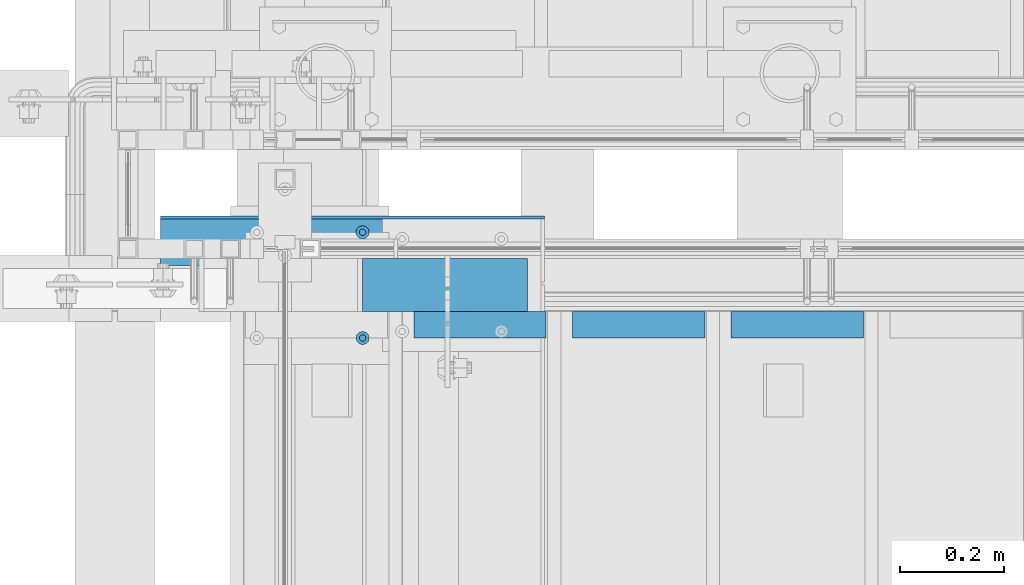
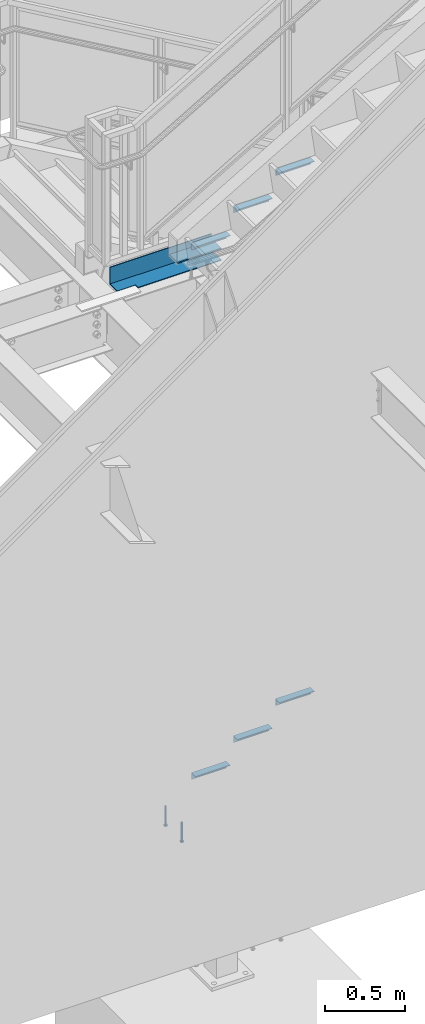
# One storey, part 913 of 1179: 10 beams, 4 elements without a shape of their own.
"""IFC2X3 building model written with IfcOpenShell, lengths in millimetres."""

from ifc_helpers import new_model, si_unit, frame, origin_with_axes, place, context, subcontext, project, spatial, faceted_brep, material, type_object, element, aggregate, save


model = new_model("IFC2X3")

# Units and contexts
model_context = context("Model", 3, precision=1e-05, world=origin_with_axes())
body_context = subcontext(model_context, "Body", "Model", "MODEL_VIEW")
ifc_project = project(units=[si_unit("LENGTHUNIT", "METRE", prefix="MILLI"), si_unit("AREAUNIT", "SQUARE_METRE"), si_unit("VOLUMEUNIT", "CUBIC_METRE"), si_unit("MASSUNIT", "GRAM", prefix="KILO"), si_unit("TIMEUNIT", "SECOND"), si_unit("PLANEANGLEUNIT", "RADIAN"), si_unit("SOLIDANGLEUNIT", "STERADIAN"), si_unit("THERMODYNAMICTEMPERATUREUNIT", "DEGREE_CELSIUS"), si_unit("LUMINOUSINTENSITYUNIT", "LUMEN")], contexts=[model_context])

# Site, building, storey
site_placement = place(None, origin_with_axes())
site = spatial("IfcSite", under=ifc_project, at=site_placement, CompositionType="ELEMENT")
building_placement = place(site_placement, origin_with_axes())
building = spatial("IfcBuilding", under=site, at=building_placement, Name="Undefined", CompositionType="ELEMENT")
storey_placement = place(building_placement, origin_with_axes())
storey = spatial("IfcBuildingStorey", under=building, at=storey_placement, Name="Undefined", CompositionType="ELEMENT", Elevation=0.0)

# Assembly, beams
assembly_1_placement = place(storey_placement, origin_with_axes())
assembly_1 = element("IfcElementAssembly", 1, at=assembly_1_placement, inside=storey, Name="STAIR", AssemblyPlace="NOTDEFINED", PredefinedType="RIGID_FRAME")
ifc_material_1 = material(Name="STEEL/A36")
beam_type_1 = type_object("IfcBeamType", Name="L2X2X3/16", PredefinedType="NOTDEFINED")
beam_1_placement = place(assembly_1_placement, frame((20463.213033546, 39325.5499999802, 4690.07030000019), z_axis=(0.0, -1.0, 0.0), x_axis=(1.0, 0.0, 0.0)))
beam_1 = element("IfcBeam", 2, at=beam_1_placement, type_object=beam_type_1, material=ifc_material_1, Name="ANGLE", ObjectType="L2X2X3/16", context=body_context, shape_type="Brep", body=[
    faceted_brep([(0.0, 25.3999999999996, -25.4000000000015), (0.0, 25.3999999999996, 25.4000000000015), (254.0, 25.3999999999996, 25.4000000000001), (254.0, 25.3999999999996, -25.4000000000001), (0.0, 20.6374999999998, 25.4000000000015), (254.0, 20.6374999999998, 25.4000000000001), (0.0, 20.6374999999998, -20.6374999999971), (254.0, 20.6374999999998, -20.6374999999998), (0.0, -25.3999999999996, -20.6374999999971), (254.0, -25.3999999999996, -20.6374999999998), (0.0, -25.3999999999996, -25.4000000000015), (254.0, -25.3999999999996, -25.4000000000001)], [[[0, 1, 2, 3]], [[1, 4, 5, 2]], [[4, 6, 7, 5]], [[6, 8, 9, 7]], [[8, 10, 11, 9]], [[10, 0, 3, 11]], [[5, 7, 9, 11, 3, 2]], [[10, 8, 6, 4, 1, 0]]]),
])
beam_2_placement = place(assembly_1_placement, frame((20158.4130335689, 39325.5499999802, 4512.27030000019), z_axis=(0.0, -1.0, 0.0), x_axis=(1.0, 0.0, 0.0)))
beam_2 = element("IfcBeam", 3, at=beam_2_placement, type_object=beam_type_1, material=ifc_material_1, Name="ANGLE", ObjectType="L2X2X3/16", context=body_context, shape_type="Brep", body=[
    faceted_brep([(0.0, 25.3999999999996, -25.4000000000015), (0.0, 25.3999999999996, 25.4000000000015), (254.0, 25.3999999999996, 25.4000000000001), (254.0, 25.3999999999996, -25.4000000000001), (0.0, 20.6374999999998, 25.4000000000015), (254.0, 20.6374999999998, 25.4000000000001), (0.0, 20.6374999999998, -20.6374999999971), (254.0, 20.6374999999998, -20.6374999999998), (0.0, -25.3999999999996, -20.6374999999971), (254.0, -25.3999999999996, -20.6374999999998), (0.0, -25.3999999999996, -25.4000000000015), (254.0, -25.3999999999996, -25.4000000000001)], [[[0, 1, 2, 3]], [[1, 4, 5, 2]], [[4, 6, 7, 5]], [[6, 8, 9, 7]], [[8, 10, 11, 9]], [[10, 0, 3, 11]], [[5, 7, 9, 11, 3, 2]], [[10, 8, 6, 4, 1, 0]]]),
])
beam_3_placement = place(assembly_1_placement, frame((19853.6130335918, 39325.5499999802, 4334.47030000019), z_axis=(0.0, -1.0, 0.0), x_axis=(1.0, 0.0, 0.0)))
beam_3 = element("IfcBeam", 4, at=beam_3_placement, type_object=beam_type_1, material=ifc_material_1, Name="ANGLE", ObjectType="L2X2X3/16", context=body_context, shape_type="Brep", body=[
    faceted_brep([(0.0, 25.3999999999996, -25.4000000000015), (0.0, 25.3999999999996, 25.4000000000015), (254.0, 25.3999999999996, 25.4000000000001), (254.0, 25.3999999999996, -25.4000000000001), (0.0, 20.6374999999998, 25.4000000000015), (254.0, 20.6374999999998, 25.4000000000001), (0.0, 20.6374999999998, -20.6374999999971), (254.0, 20.6374999999998, -20.6374999999998), (0.0, -25.3999999999996, -20.6374999999971), (254.0, -25.3999999999996, -20.6374999999998), (0.0, -25.3999999999996, -25.4000000000015), (254.0, -25.3999999999996, -25.4000000000001)], [[[0, 1, 2, 3]], [[1, 4, 5, 2]], [[4, 6, 7, 5]], [[6, 8, 9, 7]], [[8, 10, 11, 9]], [[10, 0, 3, 11]], [[5, 7, 9, 11, 3, 2]], [[10, 8, 6, 4, 1, 0]]]),
])

assembly_2_placement = place(storey_placement, origin_with_axes())
assembly_2 = element("IfcElementAssembly", 5, at=assembly_2_placement, inside=storey, Name="STAIR", AssemblyPlace="NOTDEFINED", PredefinedType="RIGID_FRAME")
beam_4_placement = place(assembly_2_placement, frame((20463.2678270794, 39325.5500000012, 627.128633125554), z_axis=(0.0, -1.0, 0.0), x_axis=(1.0, 0.0, 0.0)))
beam_4 = element("IfcBeam", 6, at=beam_4_placement, type_object=beam_type_1, material=ifc_material_1, Name="ANGLE", ObjectType="L2X2X3/16", context=body_context, shape_type="Brep", body=[
    faceted_brep([(0.0, 25.3999999999996, -25.4000000000015), (0.0, 25.3999999999996, 25.4000000000015), (254.0, 25.3999999999996, 25.4000000000001), (254.0, 25.3999999999996, -25.4000000000001), (0.0, 20.6374999999998, 25.4000000000015), (254.0, 20.6374999999998, 25.4000000000001), (0.0, 20.6374999999998, -20.6374999999971), (254.0, 20.6374999999998, -20.6374999999998), (0.0, -25.3999999999996, -20.6374999999971), (254.0, -25.3999999999996, -20.6374999999998), (0.0, -25.3999999999996, -25.4000000000015), (254.0, -25.3999999999996, -25.4000000000001)], [[[0, 1, 2, 3]], [[1, 4, 5, 2]], [[4, 6, 7, 5]], [[6, 8, 9, 7]], [[8, 10, 11, 9]], [[10, 0, 3, 11]], [[5, 7, 9, 11, 3, 2]], [[10, 8, 6, 4, 1, 0]]]),
])
beam_5_placement = place(assembly_2_placement, frame((20158.4678270527, 39325.5500000025, 450.651549846355), z_axis=(0.0, -1.0, 0.0), x_axis=(1.0, 0.0, 0.0)))
beam_5 = element("IfcBeam", 7, at=beam_5_placement, type_object=beam_type_1, material=ifc_material_1, Name="ANGLE", ObjectType="L2X2X3/16", context=body_context, shape_type="Brep", body=[
    faceted_brep([(0.0, 25.3999999999996, -25.4000000000015), (0.0, 25.3999999999996, 25.4000000000015), (254.0, 25.3999999999996, 25.4000000000001), (254.0, 25.3999999999996, -25.4000000000001), (0.0, 20.6374999999998, 25.4000000000015), (254.0, 20.6374999999998, 25.4000000000001), (0.0, 20.6374999999998, -20.6374999999971), (254.0, 20.6374999999998, -20.6374999999998), (0.0, -25.3999999999996, -20.6374999999971), (254.0, -25.3999999999996, -20.6374999999998), (0.0, -25.3999999999996, -25.4000000000015), (254.0, -25.3999999999996, -25.4000000000001)], [[[0, 1, 2, 3]], [[1, 4, 5, 2]], [[4, 6, 7, 5]], [[6, 8, 9, 7]], [[8, 10, 11, 9]], [[10, 0, 3, 11]], [[5, 7, 9, 11, 3, 2]], [[10, 8, 6, 4, 1, 0]]]),
])
beam_6_placement = place(assembly_2_placement, frame((19853.6678270259, 39325.5500000038, 274.174466567156), z_axis=(0.0, -1.0, 0.0), x_axis=(1.0, 0.0, 0.0)))
beam_6 = element("IfcBeam", 8, at=beam_6_placement, type_object=beam_type_1, material=ifc_material_1, Name="ANGLE", ObjectType="L2X2X3/16", context=body_context, shape_type="Brep", body=[
    faceted_brep([(0.0, 25.3999999999996, -25.4000000000015), (0.0, 25.3999999999996, 25.4000000000015), (254.0, 25.3999999999996, 25.4000000000001), (254.0, 25.3999999999996, -25.4000000000001), (0.0, 20.6374999999998, 25.4000000000015), (254.0, 20.6374999999998, 25.4000000000001), (0.0, 20.6374999999998, -20.6374999999971), (254.0, 20.6374999999998, -20.6374999999998), (0.0, -25.3999999999996, -20.6374999999971), (254.0, -25.3999999999996, -20.6374999999998), (0.0, -25.3999999999996, -25.4000000000015), (254.0, -25.3999999999996, -25.4000000000001)], [[[0, 1, 2, 3]], [[1, 4, 5, 2]], [[4, 6, 7, 5]], [[6, 8, 9, 7]], [[8, 10, 11, 9]], [[10, 0, 3, 11]], [[5, 7, 9, 11, 3, 2]], [[10, 8, 6, 4, 1, 0]]]),
])
aggregate(assembly_2, [beam_4, beam_5, beam_6])

assembly_3_placement = place(storey_placement, origin_with_axes())
assembly_3 = element("IfcElementAssembly", 9, at=assembly_3_placement, inside=storey, Name="EMBED", AssemblyPlace="NOTDEFINED", PredefinedType="RIGID_FRAME")
ifc_material_2 = material(Name="STEEL/A108")
beam_type_2 = type_object("IfcBeamType", Name="STUD_1/2-DIA", PredefinedType="NOTDEFINED")
beam_7_placement = place(assembly_3_placement, frame((19754.8500003795, 39300.1499999899, -12.6999999999998), z_axis=(0.0, -1.0, 0.0), x_axis=(0.0, 0.0, -1.0)))
beam_7 = element("IfcBeam", 10, at=beam_7_placement, type_object=beam_type_2, material=ifc_material_2, Name="SHEAR STUD", ObjectType="STUD_1/2-DIA", context=body_context, shape_type="Brep", body=[
    faceted_brep([(0.0, -3.1800000667572, 5.5), (0.0, -5.5, 3.1800000667572), (141.732, -5.5, 3.1800000667572), (141.732, -3.1800000667572, 5.5), (0.0, -6.34999999999854, 0.0), (141.732, -6.34999990463257, 0.0), (0.0, -5.5, -3.1800000667572), (141.732, -5.5, -3.1800000667572), (0.0, -3.1800000667572, -5.5), (141.732, -3.1800000667572, -5.5), (0.0, 0.0, -6.34999999999991), (141.732, 0.0, -6.34999990463257), (0.0, 3.1800000667572, -5.5), (141.732, 3.1800000667572, -5.5), (0.0, 5.5, -3.1800000667572), (141.732, 5.5, -3.1800000667572), (0.0, 6.34999999999854, 0.0), (141.732, 6.34999990463257, 0.0), (0.0, 5.5, 3.1800000667572), (141.732, 5.5, 3.1800000667572), (0.0, 3.1800000667572, 5.5), (141.732, 3.1800000667572, 5.5), (0.0, 0.0, 6.34999999999991), (141.732, 0.0, 6.34999990463257), (144.78, -10.9899997711182, 6.34999990463257), (144.78, -6.34000015258789, 10.9899997711182), (144.78, -12.6999998092651, 0.0), (144.78, -10.9899997711182, -6.34999990463257), (144.78, -6.34000015258789, -10.9899997711182), (144.78, 0.0, -12.6899995803833), (144.78, 6.34000015258789, -10.9899997711182), (144.78, 10.9899997711182, -6.34999990463257), (144.78, 12.6999998092651, 0.0), (144.78, 10.9899997711182, 6.34999990463257), (144.78, 6.34000015258789, 10.9899997711182), (144.78, 0.0, 12.6899995803833), (152.4, -10.9899997711182, 6.34999990463257), (152.4, -6.34000015258789, 10.9899997711182), (152.4, -12.6999998092651, 0.0), (152.4, -10.9899997711182, -6.34999990463257), (152.4, -6.34000015258789, -10.9899997711182), (152.4, 0.0, -12.6899995803833), (152.4, 6.34000015258789, -10.9899997711182), (152.4, 10.9899997711182, -6.34999990463257), (152.4, 12.6999998092651, 0.0), (152.4, 10.9899997711182, 6.34999990463257), (152.4, 6.34000015258789, 10.9899997711182), (152.4, 0.0, 12.6899995803833)], [[[0, 1, 2, 3]], [[1, 4, 5, 2]], [[4, 6, 7, 5]], [[6, 8, 9, 7]], [[8, 10, 11, 9]], [[10, 12, 13, 11]], [[12, 14, 15, 13]], [[14, 16, 17, 15]], [[16, 18, 19, 17]], [[18, 20, 21, 19]], [[20, 22, 23, 21]], [[22, 0, 3, 23]], [[22, 20, 18, 16, 14, 12, 10, 8, 6, 4, 1, 0]], [[3, 2, 24, 25]], [[2, 5, 26, 24]], [[5, 7, 27, 26]], [[7, 9, 28, 27]], [[9, 11, 29, 28]], [[11, 13, 30, 29]], [[13, 15, 31, 30]], [[15, 17, 32, 31]], [[17, 19, 33, 32]], [[19, 21, 34, 33]], [[21, 23, 35, 34]], [[23, 3, 25, 35]], [[25, 24, 36, 37]], [[24, 26, 38, 36]], [[26, 27, 39, 38]], [[27, 28, 40, 39]], [[28, 29, 41, 40]], [[29, 30, 42, 41]], [[30, 31, 43, 42]], [[31, 32, 44, 43]], [[32, 33, 45, 44]], [[33, 34, 46, 45]], [[34, 35, 47, 46]], [[35, 25, 37, 47]], [[38, 39, 40, 41, 42, 43, 44, 45, 46, 47, 37, 36]]]),
])
beam_8_placement = place(assembly_3_placement, frame((19754.8500003795, 39503.3499999899, -12.6999999999998), z_axis=(0.0, -1.0, 0.0), x_axis=(0.0, 0.0, -1.0)))
beam_8 = element("IfcBeam", 11, at=beam_8_placement, type_object=beam_type_2, material=ifc_material_2, Name="SHEAR STUD", ObjectType="STUD_1/2-DIA", context=body_context, shape_type="Brep", body=[
    faceted_brep([(0.0, -3.1800000667572, 5.5), (0.0, -5.5, 3.1800000667572), (141.732, -5.5, 3.1800000667572), (141.732, -3.1800000667572, 5.5), (0.0, -6.34999999999854, 0.0), (141.732, -6.34999990463257, 0.0), (0.0, -5.5, -3.1800000667572), (141.732, -5.5, -3.1800000667572), (0.0, -3.1800000667572, -5.5), (141.732, -3.1800000667572, -5.5), (0.0, 0.0, -6.34999999999991), (141.732, 0.0, -6.34999990463257), (0.0, 3.1800000667572, -5.5), (141.732, 3.1800000667572, -5.5), (0.0, 5.5, -3.1800000667572), (141.732, 5.5, -3.1800000667572), (0.0, 6.34999999999854, 0.0), (141.732, 6.34999990463257, 0.0), (0.0, 5.5, 3.1800000667572), (141.732, 5.5, 3.1800000667572), (0.0, 3.1800000667572, 5.5), (141.732, 3.1800000667572, 5.5), (0.0, 0.0, 6.34999999999991), (141.732, 0.0, 6.34999990463257), (144.78, -10.9899997711182, 6.34999990463257), (144.78, -6.34000015258789, 10.9899997711182), (144.78, -12.6999998092651, 0.0), (144.78, -10.9899997711182, -6.34999990463257), (144.78, -6.34000015258789, -10.9899997711182), (144.78, 0.0, -12.6899995803833), (144.78, 6.34000015258789, -10.9899997711182), (144.78, 10.9899997711182, -6.34999990463257), (144.78, 12.6999998092651, 0.0), (144.78, 10.9899997711182, 6.34999990463257), (144.78, 6.34000015258789, 10.9899997711182), (144.78, 0.0, 12.6899995803833), (152.4, -10.9899997711182, 6.34999990463257), (152.4, -6.34000015258789, 10.9899997711182), (152.4, -12.6999998092651, 0.0), (152.4, -10.9899997711182, -6.34999990463257), (152.4, -6.34000015258789, -10.9899997711182), (152.4, 0.0, -12.6899995803833), (152.4, 6.34000015258789, -10.9899997711182), (152.4, 10.9899997711182, -6.34999990463257), (152.4, 12.6999998092651, 0.0), (152.4, 10.9899997711182, 6.34999990463257), (152.4, 6.34000015258789, 10.9899997711182), (152.4, 0.0, 12.6899995803833)], [[[0, 1, 2, 3]], [[1, 4, 5, 2]], [[4, 6, 7, 5]], [[6, 8, 9, 7]], [[8, 10, 11, 9]], [[10, 12, 13, 11]], [[12, 14, 15, 13]], [[14, 16, 17, 15]], [[16, 18, 19, 17]], [[18, 20, 21, 19]], [[20, 22, 23, 21]], [[22, 0, 3, 23]], [[22, 20, 18, 16, 14, 12, 10, 8, 6, 4, 1, 0]], [[3, 2, 24, 25]], [[2, 5, 26, 24]], [[5, 7, 27, 26]], [[7, 9, 28, 27]], [[9, 11, 29, 28]], [[11, 13, 30, 29]], [[13, 15, 31, 30]], [[15, 17, 32, 31]], [[17, 19, 33, 32]], [[19, 21, 34, 33]], [[21, 23, 35, 34]], [[23, 3, 25, 35]], [[25, 24, 36, 37]], [[24, 26, 38, 36]], [[26, 27, 39, 38]], [[27, 28, 40, 39]], [[28, 29, 41, 40]], [[29, 30, 42, 41]], [[30, 31, 43, 42]], [[31, 32, 44, 43]], [[32, 33, 45, 44]], [[33, 34, 46, 45]], [[34, 35, 47, 46]], [[35, 25, 37, 47]], [[38, 39, 40, 41, 42, 43, 44, 45, 46, 47, 37, 36]]]),
])
aggregate(assembly_3, [beam_7, beam_8])

# Beam
beam_type_3 = type_object("IfcBeamType", PredefinedType="NOTDEFINED")
beam_9_placement = place(assembly_1_placement, frame((19754.8499998159, 39401.7500000084, 4240.21250023228), z_axis=(0.0, -1.0, 0.0), x_axis=(1.0, 0.0, 0.0)))
beam_9 = element("IfcBeam", 12, at=beam_9_placement, type_object=beam_type_3, material=ifc_material_1, Name="PLATE", context=body_context, shape_type="Brep", body=[
    faceted_brep([(0.0, 4.76249999999982, -50.7999999999993), (0.0, 4.76249999999982, 50.7999999999993), (316.835553113491, 4.76250000001255, 50.8000000000029), (316.835553113491, 4.76250000001255, -50.8000000000029), (0.0, -4.76249999999982, 50.7999999999993), (316.835553113473, -4.76249999998709, 50.8000000000029), (0.0, -4.76249999999982, -50.7999999999993), (316.835553113473, -4.76249999998709, -50.8000000000029)], [[[0, 1, 2, 3]], [[1, 4, 5, 2]], [[4, 6, 7, 5]], [[6, 0, 3, 7]], [[5, 7, 3, 2]], [[6, 4, 1, 0]]]),
])

aggregate(assembly_1, [beam_9, beam_1, beam_2, beam_3])

# Assembly, beam
assembly_4_placement = place(storey_placement, origin_with_axes())
assembly_4 = element("IfcElementAssembly", 13, at=assembly_4_placement, inside=storey, Name="BEAM", AssemblyPlace="NOTDEFINED", PredefinedType="RIGID_FRAME")
beam_type_4 = type_object("IfcBeamType", PredefinedType="NOTDEFINED")
beam_10_placement = place(assembly_4_placement, frame((19735.40325, 39408.1000000093, 4105.275), z_axis=(-1.0, 0.0, 0.0), x_axis=(0.0, 1.0, 0.0)))
beam_10 = element("IfcBeam", 14, at=beam_10_placement, type_object=beam_type_4, material=ifc_material_1, Name="BENT_PLATE", context=body_context, shape_type="Brep", body=[
    faceted_brep([(31.7499999999927, -3.17500000000018, 235.347000000005), (31.7499999999927, 3.17500000000018, 235.347000000005), (0.0, 3.17500000000018, 235.347000000005), (0.0, -3.17500000000018, 235.347000000005), (31.7499999814027, -3.17500000000018, 368.696500000005), (31.7499999999927, 3.17500000000018, 368.697), (120.649999999994, -3.17500000000018, -368.697), (0.0, -3.17500000000018, -368.697), (0.0, 3.17500000000018, -368.697), (127.0, 3.17500000000018, -368.697), (127.0, -130.175, -368.697), (120.649999999994, -130.175, -368.697), (127.0, 3.17500000000018, 368.697), (127.0, -130.175, 368.697), (120.649999999994, -130.175, 368.697), (120.649999999994, -3.17500000000018, 368.697)], [[[0, 1, 2, 3]], [[4, 5, 1, 0]], [[6, 7, 8, 9, 10, 11]], [[9, 12, 13, 10]], [[14, 11, 10, 13]], [[15, 6, 11, 14]], [[3, 7, 6, 15, 4, 0]], [[8, 7, 3, 2]], [[12, 9, 8, 2, 1, 5]], [[15, 14, 13, 12, 5, 4]]]),
])
aggregate(assembly_4, [beam_10])

save(model, "model.ifc")
